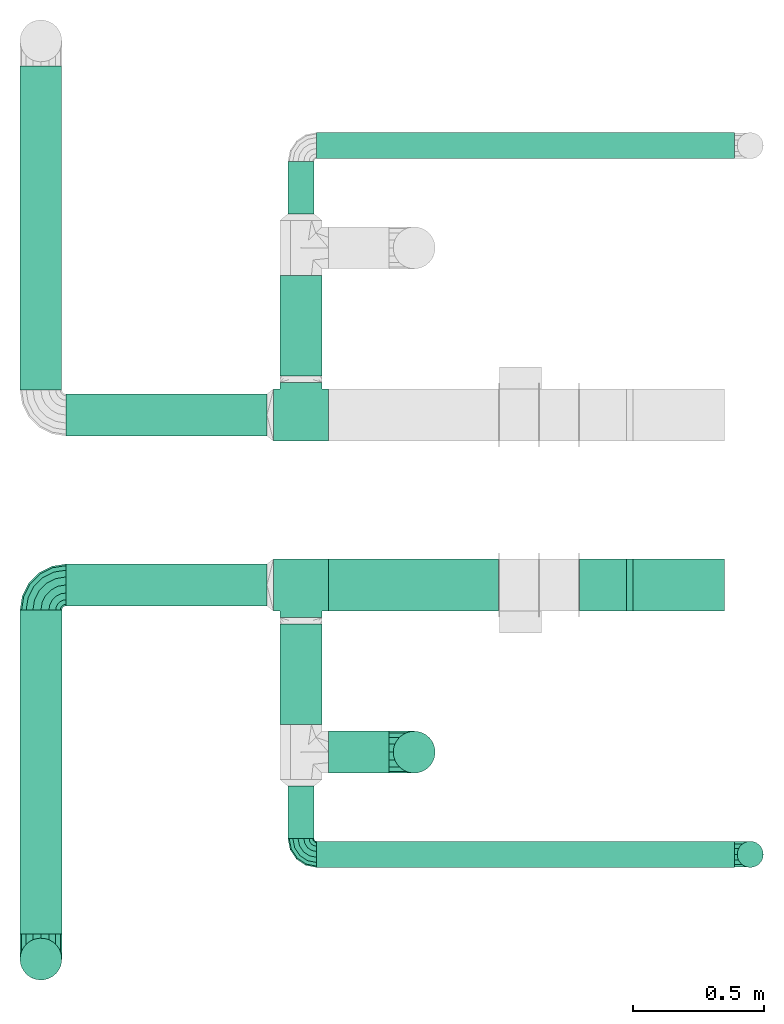
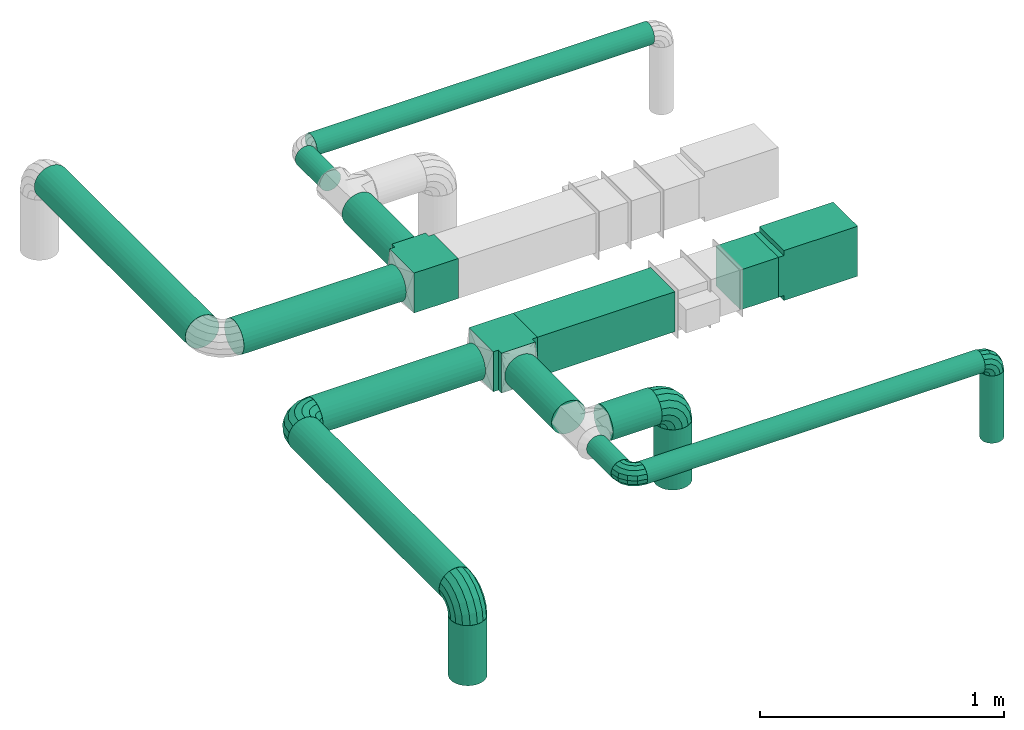
# One storey, part 1 of 5: 16 flow segments, 8 flow fittings.
"""IFC2X3 building model written with IfcOpenShell, lengths in millimetres."""

from ifc_helpers import new_model, entity, si_unit, converted_unit, derived_unit, direction, frame, frame_2d, origin, origin_2d_with_axis, place, context, subcontext, project, spatial, polyline, rectangle, circle, outline, extrude, faceted_brep, source, transform, mapped, material, type_object, type_shapes, element, save


model = new_model("IFC2X3")

# Units and contexts
model_context = context("Model", 3, precision=0.01, world=origin(), true_north=direction((6.12303176911189e-17, 1.0)))
body_context = subcontext(model_context, "Body", "Model", "MODEL_VIEW")
ifc_project = project(units=[si_unit("LENGTHUNIT", "METRE", prefix="MILLI"), si_unit("AREAUNIT", "SQUARE_METRE"), si_unit("VOLUMEUNIT", "CUBIC_METRE"), converted_unit("PLANEANGLEUNIT", "DEGREE", entity("IfcRatioMeasure", 0.0174532925199433), si_unit("PLANEANGLEUNIT", "RADIAN"), dimensions=[0, 0, 0, 0, 0, 0, 0]), si_unit("MASSUNIT", "GRAM", prefix="KILO"), derived_unit("MASSDENSITYUNIT", [(si_unit("MASSUNIT", "GRAM", prefix="KILO"), 1), (si_unit("LENGTHUNIT", "METRE"), -3)]), derived_unit("MOMENTOFINERTIAUNIT", [(si_unit("LENGTHUNIT", "METRE"), 4)]), si_unit("TIMEUNIT", "SECOND"), si_unit("FREQUENCYUNIT", "HERTZ"), si_unit("THERMODYNAMICTEMPERATUREUNIT", "DEGREE_CELSIUS"), derived_unit("THERMALTRANSMITTANCEUNIT", [(si_unit("MASSUNIT", "GRAM", prefix="KILO"), 1), (si_unit("THERMODYNAMICTEMPERATUREUNIT", "KELVIN"), -1), (si_unit("TIMEUNIT", "SECOND"), -3)]), derived_unit("VOLUMETRICFLOWRATEUNIT", [(si_unit("LENGTHUNIT", "METRE"), 3), (si_unit("TIMEUNIT", "SECOND"), -1)]), si_unit("ELECTRICCURRENTUNIT", "AMPERE"), si_unit("ELECTRICVOLTAGEUNIT", "VOLT"), si_unit("POWERUNIT", "WATT"), si_unit("FORCEUNIT", "NEWTON", prefix="KILO"), si_unit("ILLUMINANCEUNIT", "LUX"), si_unit("LUMINOUSFLUXUNIT", "LUMEN"), si_unit("LUMINOUSINTENSITYUNIT", "CANDELA"), derived_unit("USERDEFINED", [(si_unit("MASSUNIT", "GRAM", prefix="KILO"), -1), (si_unit("LENGTHUNIT", "METRE"), -2), (si_unit("TIMEUNIT", "SECOND"), 3), (si_unit("LUMINOUSFLUXUNIT", "LUMEN"), 1)]), derived_unit("LINEARVELOCITYUNIT", [(si_unit("LENGTHUNIT", "METRE"), 1), (si_unit("TIMEUNIT", "SECOND"), -1)]), si_unit("PRESSUREUNIT", "PASCAL"), derived_unit("USERDEFINED", [(si_unit("LENGTHUNIT", "METRE"), -2), (si_unit("MASSUNIT", "GRAM", prefix="KILO"), 1), (si_unit("TIMEUNIT", "SECOND"), -2)]), derived_unit("LINEARFORCEUNIT", [(si_unit("MASSUNIT", "GRAM", prefix="KILO"), 1), (si_unit("LENGTHUNIT", "METRE"), 1), (si_unit("TIMEUNIT", "SECOND"), -2), (si_unit("LENGTHUNIT", "METRE"), -1)]), derived_unit("PLANARFORCEUNIT", [(si_unit("MASSUNIT", "GRAM", prefix="KILO"), 1), (si_unit("LENGTHUNIT", "METRE"), 1), (si_unit("TIMEUNIT", "SECOND"), -2), (si_unit("LENGTHUNIT", "METRE"), -2)])], contexts=[model_context])

# Site, building, storey
site_placement = place(None, origin())
site = spatial("IfcSite", under=ifc_project, at=site_placement, CompositionType="ELEMENT")
building_placement = place(site_placement, origin())
building = spatial("IfcBuilding", under=site, at=building_placement, CompositionType="ELEMENT")
storey_placement = place(building_placement, frame((0.0, 0.0, 12000.0)))
storey = spatial("IfcBuildingStorey", under=building, at=storey_placement, Name="03 Level", CompositionType="ELEMENT", Elevation=12000.0)

# Flow segments
ifc_material = material()
duct_segment_type_1 = type_object("IfcDuctSegmentType", Name="Rectangular Duct:Air", PredefinedType="NOTDEFINED", material=ifc_material)
flow_segment_1_placement = place(storey_placement, origin())
element("IfcFlowSegment", 1, at=flow_segment_1_placement, inside=storey, type_object=duct_segment_type_1, Name="Rectangular Duct:Air", ObjectType="Rectangular Duct:Air", context=body_context, shape_type="SweptSolid", body=[
    extrude(rectangle(XDim=179.671447124557, YDim=199.999999999998, at=frame_2d((0.0, -4.33431068813661e-12), x_axis=(1.0, 0.0))), frame((24340.8257944141, -69156.0352293172, 2900.0)), (0.0, 0.0, 1.0), 199.999999999998),
])
flow_segment_2_placement = place(storey_placement, origin())
element("IfcFlowSegment", 2, at=flow_segment_2_placement, inside=storey, type_object=duct_segment_type_1, Name="Rectangular Duct:Air", ObjectType="Rectangular Duct:Air", context=body_context, shape_type="SweptSolid", body=[
    extrude(rectangle(XDim=650.000000000004, YDim=199.999999999998, at=frame_2d((-2.1600499167107e-12, -4.33431068813661e-12), x_axis=(1.0, 0.0))), frame((23615.9900708518, -69156.0352293172, 2900.0), z_axis=(0.0, 0.0, 1.0), x_axis=(-1.0, 0.0, 0.0)), (0.0, 0.0, 1.0), 199.999999999998),
])
duct_segment_type_2 = type_object("IfcDuctSegmentType", Name="Round Duct:Air", PredefinedType="NOTDEFINED", material=ifc_material)
flow_segment_3_placement = place(storey_placement, origin())
element("IfcFlowSegment", 3, at=flow_segment_3_placement, inside=storey, type_object=duct_segment_type_2, Name="Round Duct:Air", ObjectType="Round Duct:Air", context=body_context, shape_type="SweptSolid", body=[
    extrude(circle(Radius=80.0, at=origin_2d_with_axis()), frame((23290.9900708518, -69795.234231492, 3000.0), z_axis=(1.0, 0.0, 0.0), x_axis=(0.0, 1.0, 0.0)), (0.0, 0.0, 1.0), 231.770344008329),
])
flow_segment_4_placement = place(storey_placement, origin())
element("IfcFlowSegment", 4, at=flow_segment_4_placement, inside=storey, type_object=duct_segment_type_2, Name="Round Duct:Air", ObjectType="Round Duct:Air", context=body_context, shape_type="SweptSolid", body=[
    extrude(circle(Radius=50.0, at=origin_2d_with_axis()), frame((23245.9900708518, -70185.9356124915, 3000.0), z_axis=(1.0, 0.0, 0.0), x_axis=(0.0, -1.0, 0.0)), (0.0, 0.0, 1.0), 1597.50000000001),
])
flow_segment_5_placement = place(storey_placement, origin())
element("IfcFlowSegment", 5, at=flow_segment_5_placement, inside=storey, type_object=duct_segment_type_2, Name="Round Duct:Air", ObjectType="Round Duct:Air", context=body_context, shape_type="SweptSolid", body=[
    extrude(circle(Radius=50.0, at=origin_2d_with_axis()), frame((24903.4900708518, -70185.935612491, 2603.07847999999), z_axis=(0.0, 0.0, 1.0), x_axis=(0.0, 1.0, 0.0)), (0.0, 0.0, 1.0), 336.921519999948),
])
flow_segment_6_placement = place(storey_placement, origin())
element("IfcFlowSegment", 6, at=flow_segment_6_placement, inside=storey, type_object=duct_segment_type_2, Name="Round Duct:Air", ObjectType="Round Duct:Air", context=body_context, shape_type="SweptSolid", body=[
    extrude(circle(Radius=79.9999999999999, at=origin_2d_with_axis()), frame((23618.7604148601, -69795.234231492, 2603.07847999999), z_axis=(0.0, 0.0, 1.0), x_axis=(-1.0, 0.0, 0.0)), (0.0, 0.0, 1.0), 300.921520000008),
])
flow_segment_7_placement = place(storey_placement, origin())
element("IfcFlowSegment", 7, at=flow_segment_7_placement, inside=storey, type_object=duct_segment_type_2, Name="Round Duct:Air", ObjectType="Round Duct:Air", context=body_context, shape_type="SweptSolid", body=[
    extrude(circle(Radius=80.0, at=origin_2d_with_axis()), frame((22191.748982204, -70490.2395851399, 3000.0), z_axis=(0.0, 1.0, 0.0), x_axis=(1.0, 0.0, 0.0)), (0.0, 0.0, 1.0), 1238.20435582267),
])
flow_segment_8_placement = place(storey_placement, origin())
element("IfcFlowSegment", 8, at=flow_segment_8_placement, inside=storey, type_object=duct_segment_type_2, Name="Round Duct:Air", ObjectType="Round Duct:Air", context=body_context, shape_type="SweptSolid", body=[
    extrude(circle(Radius=79.9999999999999, at=origin_2d_with_axis()), frame((22191.748982204, -70586.2395851399, 2603.07847999999), z_axis=(0.0, 0.0, 1.0), x_axis=(-1.0, 0.0, 0.0)), (0.0, 0.0, 1.0), 300.921520000008),
])
flow_segment_9_placement = place(storey_placement, origin())
element("IfcFlowSegment", 9, at=flow_segment_9_placement, inside=storey, type_object=duct_segment_type_2, Name="Round Duct:Air", ObjectType="Round Duct:Air", context=body_context, shape_type="SweptSolid", body=[
    extrude(circle(Radius=80.0, at=origin_2d_with_axis()), frame((22287.748982204, -69156.0352293172, 3000.0), z_axis=(1.0, 0.0, 0.0), x_axis=(0.0, -1.0, 0.0)), (0.0, 0.0, 1.0), 768.241088647822),
])
flow_segment_10_placement = place(storey_placement, origin())
element("IfcFlowSegment", 10, at=flow_segment_10_placement, inside=storey, type_object=duct_segment_type_2, Name="Round Duct:Air", ObjectType="Round Duct:Air", context=body_context, shape_type="SweptSolid", body=[
    extrude(circle(Radius=50.0, at=origin_2d_with_axis()), frame((23185.9900708518, -70125.9356124915, 3000.0), z_axis=(0.0, 1.0, 0.0), x_axis=(1.0, 0.0, 0.0)), (0.0, 0.0, 1.0), 200.701380999497),
])
flow_segment_11_placement = place(storey_placement, origin())
element("IfcFlowSegment", 11, at=flow_segment_11_placement, inside=storey, type_object=duct_segment_type_2, Name="Round Duct:Air", ObjectType="Round Duct:Air", context=body_context, shape_type="SweptSolid", body=[
    extrude(circle(Radius=80.0, at=origin_2d_with_axis()), frame((23185.9900708518, -69690.234231492, 3000.0), z_axis=(0.0, 1.0, 0.0), x_axis=(1.0, 0.0, 0.0)), (0.0, 0.0, 1.0), 384.199002174792),
])
flow_segment_12_placement = place(storey_placement, origin())
element("IfcFlowSegment", 12, at=flow_segment_12_placement, inside=storey, type_object=duct_segment_type_2, Name="Round Duct:Air", ObjectType="Round Duct:Air", context=body_context, shape_type="SweptSolid", body=[
    extrude(circle(Radius=50.0, at=origin_2d_with_axis()), frame((23245.9900708518, -67476.5435577883, 3000.0), z_axis=(1.0, 0.0, 0.0), x_axis=(0.0, -1.0, 0.0)), (0.0, 0.0, 1.0), 1597.50000000001),
])
flow_segment_13_placement = place(storey_placement, origin())
element("IfcFlowSegment", 13, at=flow_segment_13_placement, inside=storey, type_object=duct_segment_type_2, Name="Round Duct:Air", ObjectType="Round Duct:Air", context=body_context, shape_type="SweptSolid", body=[
    extrude(circle(Radius=80.0, at=frame_2d((-4.33146851719357e-12, 0.0), x_axis=(1.0, 0.0))), frame((22191.748982204, -68410.4439409626, 3000.0), z_axis=(0.0, 1.0, 0.0), x_axis=(-1.0, 0.0, 0.0)), (0.0, 0.0, 1.0), 1238.20435582267),
])
flow_segment_14_placement = place(storey_placement, origin())
element("IfcFlowSegment", 14, at=flow_segment_14_placement, inside=storey, type_object=duct_segment_type_2, Name="Round Duct:Air", ObjectType="Round Duct:Air", context=body_context, shape_type="SweptSolid", body=[
    extrude(circle(Radius=80.0, at=origin_2d_with_axis()), frame((22287.748982204, -68506.4439409626, 3000.0), z_axis=(1.0, 0.0, 0.0), x_axis=(0.0, -1.0, 0.0)), (0.0, 0.0, 1.0), 768.241088647822),
])
flow_segment_15_placement = place(storey_placement, origin())
element("IfcFlowSegment", 15, at=flow_segment_15_placement, inside=storey, type_object=duct_segment_type_2, Name="Round Duct:Air", ObjectType="Round Duct:Air", context=body_context, shape_type="SweptSolid", body=[
    extrude(circle(Radius=50.0, at=frame_2d((0.0, 2.16573425859679e-12), x_axis=(1.0, 0.0))), frame((23185.9900708518, -67737.2449387878, 3000.0), z_axis=(0.0, 1.0, 0.0), x_axis=(-1.0, 0.0, 0.0)), (0.0, 0.0, 1.0), 200.701380999497),
])
flow_segment_16_placement = place(storey_placement, origin())
element("IfcFlowSegment", 16, at=flow_segment_16_placement, inside=storey, type_object=duct_segment_type_2, Name="Round Duct:Air", ObjectType="Round Duct:Air", context=body_context, shape_type="SweptSolid", body=[
    extrude(circle(Radius=80.0, at=frame_2d((0.0, 2.16573425859679e-12), x_axis=(1.0, 0.0))), frame((23185.9900708518, -68356.4439409626, 3000.0), z_axis=(0.0, 1.0, 0.0), x_axis=(-1.0, 0.0, 0.0)), (0.0, 0.0, 1.0), 384.199002174792),
])

# Flow fittings
duct_fitting_type_1 = type_object("IfcDuctFittingType", Name="elbow_short_001:Air_Elbow short_Circ", PredefinedType="NOTDEFINED")
shared_shape_1 = source(origin(), body_context, "Body", "Brep", [
    faceted_brep([(-17.9048224398387, -41.6267485762413, 0.0), (-19.7997011169438, -37.0521067749226, 21.6941869558777), (-60.0, -45.048443395121, 21.6941869558777), (-60.0, -50.0, 0.0), (-25.1090331870967, -24.2342452840172, 39.0915741234013), (-60.0, -31.1744900929368, 39.0915741234013), (-32.7812403191188, -5.71189877255394, 48.7463956090911), (-60.0, -11.1260466978159, 48.7463956090911), (-41.2967477970676, 14.8463548711994, 48.7463956090912), (-60.0, 11.1260466978155, 48.7463956090912), (-48.9689549290897, 33.3687013826628, 39.0915741234016), (-60.0, 31.1744900929364, 39.0915741234016), (-54.2782869992427, 46.1865628735683, 21.6941869558781), (-60.0, 45.0484433951208, 21.6941869558781), (-56.1731656763478, 50.7612046748872, 0.0), (-60.0, 50.0, 0.0), (-54.2782869992427, 46.1865628735684, -21.6941869558779), (-60.0, 45.0484433951209, -21.6941869558779), (-48.9689549290898, 33.368701382663, -39.0915741234014), (-60.0, 31.1744900929367, -39.0915741234014), (-41.2967477970677, 14.8463548711997, -48.7463956090911), (-60.0, 11.1260466978158, -48.7463956090911), (-32.7812403191189, -5.7118987725537, -48.7463956090912), (-60.0, -11.1260466978156, -48.7463956090912), (-25.1090331870967, -24.234245284017, -39.0915741234015), (-60.0, -31.1744900929366, -39.0915741234015), (-19.7997011169439, -37.0521067749224, -21.694186955878), (-60.0, -45.0484433951209, -21.694186955878), (17.7817459305218, -17.7817459305197, 0.0), (14.2804666777829, -14.2804666777808, 21.6941869558777), (4.47010021594289, -4.47010021594085, 39.0915741234013), (-9.70629006098178, 9.70629006098376, 48.7463956090911), (-25.4408961966291, 25.4408961966311, 48.7463956090912), (-39.6172864735539, 39.6172864735557, 39.0915741234016), (-49.4276529353939, 49.4276529353957, 21.6941869558781), (-52.928932188133, 52.9289321881348, 0.0), (-49.427652935394, 49.4276529353958, -21.6941869558779), (-39.617286473554, 39.6172864735559, -39.0915741234014), (-25.4408961966294, 25.4408961966313, -48.7463956090911), (-9.70629006098197, 9.70629006098394, -48.7463956090912), (4.47010021594274, -4.47010021594069, -39.0915741234015), (14.2804666777828, -14.2804666777807, -21.694186955878), (41.6267485762432, 17.9048224398409, 0.0), (37.0521067749244, 19.799701116946, 21.6941869558777), (24.234245284019, 25.1090331870988, 39.0915741234013), (5.71189877255573, 32.7812403191209, 48.7463956090911), (-14.8463548711977, 41.2967477970696, 48.7463956090912), (-33.3687013826611, 48.9689549290916, 39.0915741234016), (-46.1865628735666, 54.2782869992445, 21.6941869558781), (-50.7612046748855, 56.1731656763497, 0.0), (-46.1865628735667, 54.2782869992445, -21.6941869558779), (-33.3687013826613, 48.9689549290917, -39.0915741234014), (-14.846354871198, 41.2967477970697, -48.7463956090911), (5.71189877255549, 32.781240319121, -48.7463956090912), (24.2342452840188, 25.1090331870989, -39.0915741234015), (37.0521067749243, 19.7997011169461, -21.694186955878), (50.0, 60.0, 0.0), (45.0484433951226, 60.0, 21.6941869558777), (31.1744900929384, 60.0, 39.0915741234013), (11.1260466978175, 60.0, 48.7463956090911), (-11.1260466978139, 60.0, 48.7463956090912), (-31.1744900929348, 60.0, 39.0915741234016), (-45.0484433951192, 60.0, 21.6941869558781), (-50.0, 60.0, 0.0), (-45.0484433951193, 60.0, -21.6941869558779), (-31.1744900929351, 60.0, -39.0915741234014), (-11.1260466978142, 60.0, -48.7463956090911), (11.1260466978172, 60.0, -48.7463956090912), (31.1744900929382, 60.0, -39.0915741234015), (45.0484433951225, 60.0, -21.694186955878)], [[[0, 1, 2, 3]], [[1, 4, 5, 2]], [[4, 6, 7, 5]], [[6, 8, 9, 7]], [[8, 10, 11, 9]], [[10, 12, 13, 11]], [[12, 14, 15, 13]], [[14, 16, 17, 15]], [[16, 18, 19, 17]], [[18, 20, 21, 19]], [[20, 22, 23, 21]], [[22, 24, 25, 23]], [[24, 26, 27, 25]], [[26, 0, 3, 27]], [[28, 29, 1, 0]], [[29, 30, 4, 1]], [[30, 31, 6, 4]], [[31, 32, 8, 6]], [[32, 33, 10, 8]], [[33, 34, 12, 10]], [[34, 35, 14, 12]], [[35, 36, 16, 14]], [[36, 37, 18, 16]], [[37, 38, 20, 18]], [[38, 39, 22, 20]], [[39, 40, 24, 22]], [[40, 41, 26, 24]], [[41, 28, 0, 26]], [[42, 43, 29, 28]], [[43, 44, 30, 29]], [[44, 45, 31, 30]], [[45, 46, 32, 31]], [[46, 47, 33, 32]], [[47, 48, 34, 33]], [[48, 49, 35, 34]], [[49, 50, 36, 35]], [[50, 51, 37, 36]], [[51, 52, 38, 37]], [[52, 53, 39, 38]], [[53, 54, 40, 39]], [[54, 55, 41, 40]], [[55, 42, 28, 41]], [[56, 57, 43, 42]], [[57, 58, 44, 43]], [[58, 59, 45, 44]], [[59, 60, 46, 45]], [[60, 61, 47, 46]], [[61, 62, 48, 47]], [[62, 63, 49, 48]], [[63, 64, 50, 49]], [[64, 65, 51, 50]], [[65, 66, 52, 51]], [[66, 67, 53, 52]], [[67, 68, 54, 53]], [[68, 69, 55, 54]], [[69, 56, 42, 55]], [[3, 2, 5, 7, 9, 11, 13, 15, 17, 19, 21, 23, 25, 27]], [[69, 68, 67, 66, 65, 64, 63, 62, 61, 60, 59, 58, 57, 56]]]),
])
type_shapes(duct_fitting_type_1, [shared_shape_1])
for number, where, z_axis, x_axis, name in (
    (17, (24903.4900708518, -70185.9356124915, 3000.0), (0.0, -1.0, 0.0), (0.0, 0.0, 1.0), "elbow_short_001:Air_Elbow short_Circ"),
    (18, (23185.9900708518, -70185.9356124915, 3000.0), (0.0, 0.0, 1.0), (0.0, -1.0, 0.0), "elbow_short_001:Air_Elbow short_Circ"),
):
    element("IfcFlowFitting", number, at=place(storey_placement, frame(where, z_axis=z_axis, x_axis=x_axis)), inside=storey, type_object=duct_fitting_type_1, Name=name, ObjectType="elbow_short_001:Air_Elbow short_Circ", context=body_context, shape_type="MappedRepresentation", body=[
        mapped(shared_shape_1, transform((0.0, 0.0, 0.0), scale=1.0)),
    ])
duct_fitting_type_2 = type_object("IfcDuctFittingType", Name="elbow_short_001:Air_Elbow short_Circ", PredefinedType="NOTDEFINED")
shared_shape_2 = source(origin(), body_context, "Body", "Brep", [
    faceted_brep([(-41.6130089900078, -71.3859468679469, 0.0), (-43.49481043591, -65.594357537661, 30.6146745892069), (-96.0, -73.9103626009031, 30.6146745892069), (-96.0, -80.0, 0.0), (-48.8537275620507, -49.1013065214514, 56.5685424949236), (-96.0, -56.568542494924, 56.5685424949236), (-56.8739138146797, -24.417711326656, 73.9103626009028), (-96.0, -30.6146745892075, 73.9103626009028), (-66.3343685400036, 4.69857443566504, 80.0), (-96.0, 0.0, 80.0), (-75.7948232653275, 33.8148601979862, 73.9103626009031), (-96.0, 30.6146745892068, 73.9103626009031), (-83.8150095179566, 58.4984553927817, 56.5685424949241), (-96.0, 56.5685424949235, 56.5685424949241), (-89.1739266440973, 74.9915064089916, 30.6146745892076), (-96.0, 73.9103626009028, 30.6146745892076), (-91.0557280899996, 80.7830957392776, 0.0), (-96.0, 80.0, 0.0), (-89.1739266440974, 74.9915064089917, -30.6146745892072), (-96.0, 73.910362600903, -30.6146745892072), (-83.8150095179567, 58.498455392782, -56.5685424949238), (-96.0, 56.5685424949238, -56.5685424949238), (-75.7948232653277, 33.8148601979866, -73.9103626009029), (-96.0, 30.6146745892072, -73.9103626009029), (-66.3343685400037, 4.69857443566549, -80.0), (-96.0, 0.0, -80.0), (-56.8739138146798, -24.4177113266556, -73.910362600903), (-96.0, -30.614674589207, -73.910362600903), (-48.8537275620508, -49.1013065214511, -56.5685424949239), (-96.0, -56.5685424949237, -56.5685424949239), (-43.49481043591, -65.5943575376609, -30.6146745892074), (-96.0, -73.9103626009029, -30.6146745892074), (7.45020440347688, -46.3869910099904, 0.0), (3.870805348479, -41.4603708645397, 30.6146745892069), (-6.3224607577246, -27.4305436854095, 56.5685424949236), (-21.5777615526518, -6.43342347992235, 73.9103626009028), (-39.5726157799209, 18.334368540005, 80.0), (-57.56747000719, 43.1021605599325, 73.9103626009031), (-72.8227708021173, 64.0992807654198, 56.5685424949241), (-83.016036908321, 78.1291079445502, 30.6146745892076), (-86.595435963319, 83.0557280900011, 0.0), (-83.0160369083211, 78.1291079445503, -30.6146745892072), (-72.8227708021175, 64.0992807654201, -56.5685424949238), (-57.5674700071903, 43.1021605599328, -73.9103626009029), (-39.5726157799211, 18.3343685400054, -80.0), (-21.577761552652, -6.43342347992199, -73.910362600903), (-6.32246075772479, -27.4305436854093, -56.5685424949239), (3.87080534847889, -41.4603708645395, -30.6146745892074), (46.3869910099924, -7.45020440347469, 0.0), (41.4603708645417, -3.87080534847682, 30.6146745892069), (27.4305436854115, 6.32246075772673, 56.5685424949236), (6.43342347992429, 21.5777615526538, 73.9103626009028), (-18.3343685400031, 39.5726157799229, 80.0), (-43.1021605599306, 57.5674700071919, 73.9103626009031), (-64.099280765418, 72.8227708021191, 56.5685424949241), (-78.1291079445484, 83.0160369083228, 30.6146745892076), (-83.0557280899993, 86.5954359633209, 0.0), (-78.1291079445485, 83.0160369083229, -30.6146745892072), (-64.0992807654183, 72.8227708021193, -56.5685424949238), (-43.102160559931, 57.5674700071922, -73.9103626009029), (-18.3343685400035, 39.5726157799231, -80.0), (6.43342347992393, 21.5777615526541, -73.910362600903), (27.4305436854113, 6.32246075772691, -56.5685424949239), (41.4603708645416, -3.87080534847672, -30.6146745892074), (71.3859468679487, 41.6130089900101, 0.0), (65.5943575376629, 43.4948104359123, 30.6146745892069), (49.1013065214532, 48.8537275620529, 56.5685424949236), (24.4177113266578, 56.8739138146818, 73.9103626009028), (-4.69857443566324, 66.3343685400057, 80.0), (-33.8148601979844, 75.7948232653295, 73.9103626009031), (-58.4984553927799, 83.8150095179585, 56.5685424949241), (-74.9915064089898, 89.1739266440992, 30.6146745892076), (-80.7830957392759, 91.0557280900015, 0.0), (-74.99150640899, 89.1739266440993, -30.6146745892072), (-58.4984553927802, 83.8150095179586, -56.5685424949238), (-33.8148601979848, 75.7948232653297, -73.9103626009029), (-4.6985744356637, 66.3343685400058, -80.0), (24.4177113266574, 56.873913814682, -73.910362600903), (49.1013065214529, 48.853727562053, -56.5685424949239), (65.5943575376627, 43.4948104359123, -30.6146745892074), (80.0, 96.0, 0.0), (73.9103626009047, 96.0, 30.6146745892069), (56.5685424949257, 96.0, 56.5685424949236), (30.6146745892091, 96.0, 73.9103626009028), (0.0, 96.0, 80.0), (-30.6146745892051, 96.0, 73.9103626009031), (-56.5685424949219, 96.0, 56.5685424949241), (-73.9103626009011, 96.0, 30.6146745892076), (-80.0, 96.0, 0.0), (-73.9103626009013, 96.0, -30.6146745892072), (-56.5685424949222, 96.0, -56.5685424949238), (-30.6146745892056, 96.0, -73.9103626009029), (0.0, 96.0, -80.0), (30.6146745892087, 96.0, -73.910362600903), (56.5685424949254, 96.0, -56.5685424949239), (73.9103626009045, 96.0, -30.6146745892074)], [[[0, 1, 2, 3]], [[1, 4, 5, 2]], [[4, 6, 7, 5]], [[6, 8, 9, 7]], [[8, 10, 11, 9]], [[10, 12, 13, 11]], [[12, 14, 15, 13]], [[14, 16, 17, 15]], [[16, 18, 19, 17]], [[18, 20, 21, 19]], [[20, 22, 23, 21]], [[22, 24, 25, 23]], [[24, 26, 27, 25]], [[26, 28, 29, 27]], [[28, 30, 31, 29]], [[30, 0, 3, 31]], [[32, 33, 1, 0]], [[33, 34, 4, 1]], [[34, 35, 6, 4]], [[35, 36, 8, 6]], [[36, 37, 10, 8]], [[37, 38, 12, 10]], [[38, 39, 14, 12]], [[39, 40, 16, 14]], [[40, 41, 18, 16]], [[41, 42, 20, 18]], [[42, 43, 22, 20]], [[43, 44, 24, 22]], [[44, 45, 26, 24]], [[45, 46, 28, 26]], [[46, 47, 30, 28]], [[47, 32, 0, 30]], [[48, 49, 33, 32]], [[49, 50, 34, 33]], [[50, 51, 35, 34]], [[51, 52, 36, 35]], [[52, 53, 37, 36]], [[53, 54, 38, 37]], [[54, 55, 39, 38]], [[55, 56, 40, 39]], [[56, 57, 41, 40]], [[57, 58, 42, 41]], [[58, 59, 43, 42]], [[59, 60, 44, 43]], [[60, 61, 45, 44]], [[61, 62, 46, 45]], [[62, 63, 47, 46]], [[63, 48, 32, 47]], [[64, 65, 49, 48]], [[65, 66, 50, 49]], [[66, 67, 51, 50]], [[67, 68, 52, 51]], [[68, 69, 53, 52]], [[69, 70, 54, 53]], [[70, 71, 55, 54]], [[71, 72, 56, 55]], [[72, 73, 57, 56]], [[73, 74, 58, 57]], [[74, 75, 59, 58]], [[75, 76, 60, 59]], [[76, 77, 61, 60]], [[77, 78, 62, 61]], [[78, 79, 63, 62]], [[79, 64, 48, 63]], [[80, 81, 65, 64]], [[81, 82, 66, 65]], [[82, 83, 67, 66]], [[83, 84, 68, 67]], [[84, 85, 69, 68]], [[85, 86, 70, 69]], [[86, 87, 71, 70]], [[87, 88, 72, 71]], [[88, 89, 73, 72]], [[89, 90, 74, 73]], [[90, 91, 75, 74]], [[91, 92, 76, 75]], [[92, 93, 77, 76]], [[93, 94, 78, 77]], [[94, 95, 79, 78]], [[95, 80, 64, 79]], [[3, 2, 5, 7, 9, 11, 13, 15, 17, 19, 21, 23, 25, 27, 29, 31]], [[95, 94, 93, 92, 91, 90, 89, 88, 87, 86, 85, 84, 83, 82, 81, 80]]]),
])
type_shapes(duct_fitting_type_2, [shared_shape_2])
for number, where, z_axis, x_axis, name in (
    (19, (23618.7604148601, -69795.234231492, 3000.0), (0.0, -1.0, 0.0), (0.0, 0.0, 1.0), "elbow_short_001:Air_Elbow short_Circ"),
    (20, (22191.748982204, -70586.2395851399, 3000.0), (-1.0, 0.0, 0.0), (0.0, 0.0, 1.0), "elbow_short_001:Air_Elbow short_Circ"),
    (21, (22191.748982204, -69156.0352293172, 3000.0), (0.0, 0.0, 1.0), (-1.0, 0.0, 0.0), "elbow_short_001:Air_Elbow short_Circ"),
):
    element("IfcFlowFitting", number, at=place(storey_placement, frame(where, z_axis=z_axis, x_axis=x_axis)), inside=storey, type_object=duct_fitting_type_2, Name=name, ObjectType="elbow_short_001:Air_Elbow short_Circ", context=body_context, shape_type="MappedRepresentation", body=[
        mapped(shared_shape_2, transform((0.0, 0.0, 0.0), scale=1.0)),
    ])
duct_fitting_type_3 = type_object("IfcDuctFittingType", Name="1_001:Air_Rect", PredefinedType="NOTDEFINED")
shared_shape_3 = source(origin(), body_context, "Body", "SweptSolid", [
    extrude(outline(polyline([(-105.0, 43.7500000000001), (-105.0, -156.25), (105.0, -156.25), (105.0, 43.75), (80.0, 43.75), (80.0, 68.7499999999997), (-80.0, 68.7500000000002), (-80.0, 43.7500000000001), (-105.0, 43.7500000000001)])), frame((0.0, -56.25, -100.0), z_axis=(0.0, 0.0, -1.0), x_axis=(1.0, 0.0, 0.0)), (0.0, 0.0, -1.0), 200.0),
])
type_shapes(duct_fitting_type_3, [shared_shape_3])
flow_fitting_1_placement = place(storey_placement, frame((23185.9900708518, -69156.0352293172, 3000.0)))
element("IfcFlowFitting", 22, at=flow_fitting_1_placement, inside=storey, type_object=duct_fitting_type_3, Name="1_001:Air_Rect", ObjectType="1_001:Air_Rect", context=body_context, shape_type="MappedRepresentation", body=[
    mapped(shared_shape_3, transform((0.0, 0.0, 0.0), scale=1.0)),
])
duct_fitting_type_4 = type_object("IfcDuctFittingType", Name="1_001:Air_Rect", PredefinedType="NOTDEFINED")
shared_shape_4 = source(origin(), body_context, "Body", "SweptSolid", [
    extrude(outline(polyline([(-125.0, 81.25), (-125.0, -268.75), (125.0, -268.75), (125.0, 81.2500000000001), (100.0, 81.2500000000001), (100.0, 106.25), (-100.0, 106.25), (-100.0, 81.25), (-125.0, 81.25)])), frame((0.0, -93.75, -100.0), z_axis=(0.0, 0.0, -1.0), x_axis=(1.0, 0.0, 0.0)), (0.0, 0.0, -1.0), 200.0),
])
type_shapes(duct_fitting_type_4, [shared_shape_4])
flow_fitting_2_placement = place(storey_placement, frame((24630.6615179764, -69156.0352293172, 3000.0), z_axis=(0.0, -1.0, 0.0), x_axis=(0.0, 0.0, -1.0)))
element("IfcFlowFitting", 23, at=flow_fitting_2_placement, inside=storey, type_object=duct_fitting_type_4, Name="1_001:Air_Rect", ObjectType="1_001:Air_Rect", context=body_context, shape_type="MappedRepresentation", body=[
    mapped(shared_shape_4, transform((0.0, 0.0, 0.0), scale=1.0)),
])
duct_fitting_type_5 = type_object("IfcDuctFittingType", Name="1_001:Air_Rect", PredefinedType="NOTDEFINED")
shared_shape_5 = source(origin(), body_context, "Body", "SweptSolid", [
    extrude(outline(polyline([(-43.7499999999997, -105.0), (156.25, -105.0), (156.25, 105.0), (-43.7500000000004, 105.0), (-43.7500000000003, 80.0), (-68.7499999999999, 80.0), (-68.7499999999999, -80.0), (-43.7499999999998, -80.0), (-43.7499999999997, -105.0)])), frame((0.0, 56.25, -100.0), z_axis=(0.0, 0.0, 1.0), x_axis=(0.0, -1.0, 0.0)), (0.0, 0.0, 1.0), 200.0),
])
type_shapes(duct_fitting_type_5, [shared_shape_5])
flow_fitting_3_placement = place(storey_placement, frame((23185.9900708518, -68506.4439409626, 3000.0)))
element("IfcFlowFitting", 24, at=flow_fitting_3_placement, inside=storey, type_object=duct_fitting_type_5, Name="1_001:Air_Rect", ObjectType="1_001:Air_Rect", context=body_context, shape_type="MappedRepresentation", body=[
    mapped(shared_shape_5, transform((0.0, 0.0, 0.0), scale=1.0)),
])

save(model, "model.ifc")
